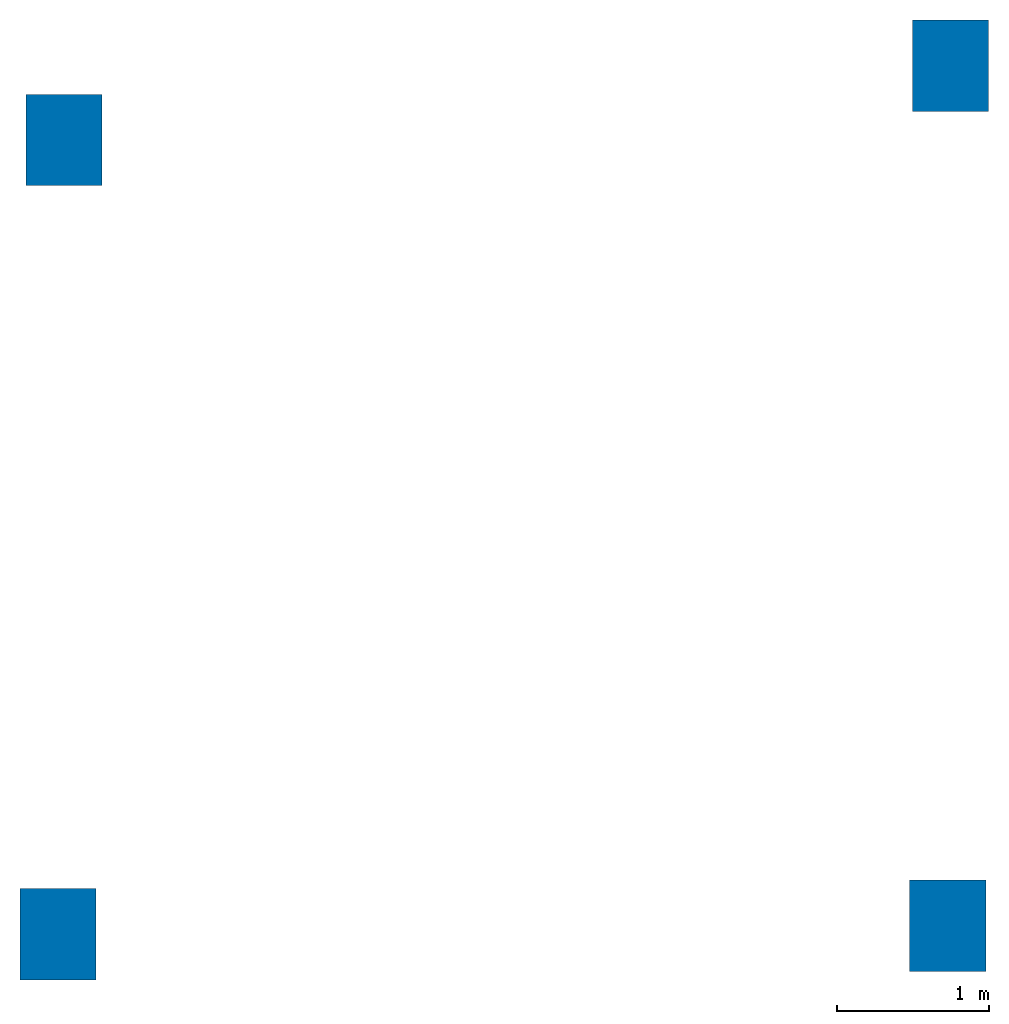
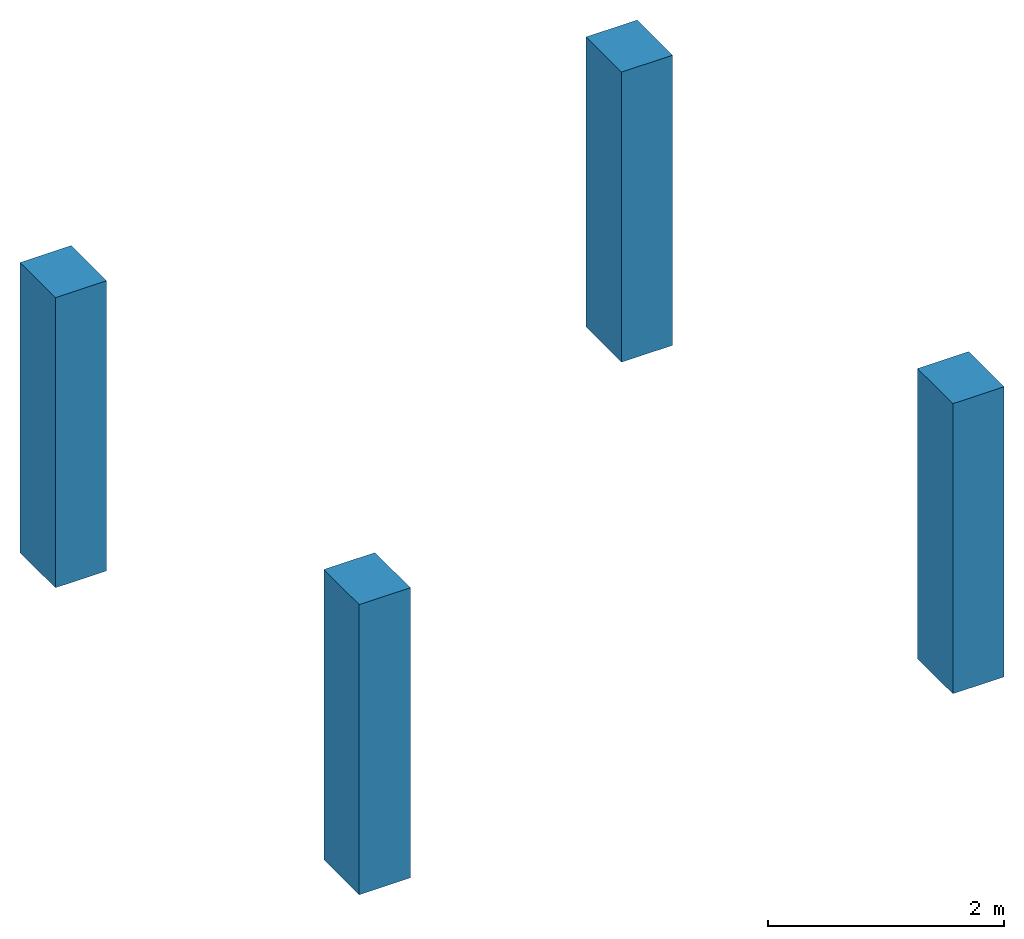
# One storey: 4 columns.
"""IFC4 building model written with IfcOpenShell, lengths in millimetres."""

import ifcopenshell
import ifcopenshell.guid

model = None  # the IFC model being written
_history = None  # IfcOwnerHistory: only IFC2X3 demands one
_inside = {}  # id of a spatial element -> (the spatial element, [elements in it])
_under = {}  # id of a project, library or spatial element -> (it, [spatial elements below it])
_declared = {}  # id of a project -> (the project, [libraries it declares])
_typed = {}  # id of a type object -> (the type object, [elements of that type])
_made_of = {}  # id of a material, layer set ... -> (it, [elements and type objects made of it])


def new_model(schema):
    """Start an empty IFC model of exactly this schema.

    Asked for "IFC4X3", IfcOpenShell would pick the latest addendum, in which some entities
    have other attributes; the version numbers below select the first issue.
    IFC2X3 requires an IfcOwnerHistory on every rooted entity: one is made here for all.
    """
    global model, _history
    if schema == "IFC4X3":
        model = ifcopenshell.file(schema_version=(4, 3, 0, 0))
    else:
        model = ifcopenshell.file(schema=schema)
    _inside.clear()
    _under.clear()
    _declared.clear()
    _typed.clear()
    _made_of.clear()
    _history = None
    if model.schema == "IFC2X3":
        org = make("IfcOrganization", Name="unknown")
        user = make(
            "IfcPersonAndOrganization",
            ThePerson=make("IfcPerson", FamilyName="unknown"),
            TheOrganization=org,
        )
        app = make(
            "IfcApplication",
            ApplicationDeveloper=org,
            Version="unknown",
            ApplicationFullName="unknown",
            ApplicationIdentifier="unknown",
        )
        _history = make(
            "IfcOwnerHistory",
            OwningUser=user,
            OwningApplication=app,
            ChangeAction="ADDED",
            CreationDate=0,
        )
    return model


def make(cls, **values):
    """One entity of the class cls with the attributes given. An attribute that is None is left unset."""
    return model.create_entity(
        cls, **{name: value for name, value in values.items() if value is not None}
    )


def entity(cls, *values):
    """Any entity or typed value of the class cls, its attributes in the order of the schema. None: left unset."""
    e = model.create_entity(cls)
    for i, value in enumerate(values):
        if value is not None:
            e[i] = value
    return e


def rooted(cls, **values):
    """An entity with a GlobalId (a new one), such as an element, a storey or a relation."""
    return make(cls, GlobalId=ifcopenshell.guid.new(), OwnerHistory=_history, **values)


def si_unit(unit_type, name, prefix=None):
    """IfcSIUnit, for example si_unit("LENGTHUNIT", "METRE", prefix="MILLI")."""
    return make("IfcSIUnit", UnitType=unit_type, Prefix=prefix, Name=name)


def converted_unit(unit_type, name, factor, base, dimensions=None, offset=None):
    """IfcConversionBasedUnit, such as the inch: factor (a typed value) times the base unit."""
    return make(
        "IfcConversionBasedUnit"
        if offset is None
        else "IfcConversionBasedUnitWithOffset",
        ConversionOffset=offset,
        Dimensions=None
        if dimensions is None
        else entity("IfcDimensionalExponents", *dimensions),
        UnitType=unit_type,
        Name=name,
        ConversionFactor=make(
            "IfcMeasureWithUnit", ValueComponent=factor, UnitComponent=base
        ),
    )


def assignment(units):
    """IfcUnitAssignment: the units of a project."""
    return None if units is None else make("IfcUnitAssignment", Units=units)


def point(xyz):
    """IfcCartesianPoint."""
    return None if xyz is None else make("IfcCartesianPoint", Coordinates=xyz)


def direction(xyz):
    """IfcDirection."""
    return None if xyz is None else make("IfcDirection", DirectionRatios=xyz)


def frame(location, z_axis=None, x_axis=None):
    """IfcAxis2Placement3D, a coordinate frame: its origin and axes. An axis left out is left unset."""
    return make(
        "IfcAxis2Placement3D",
        Location=point(location),
        Axis=direction(z_axis),
        RefDirection=direction(x_axis),
    )


def frame_2d(location, x_axis=None):
    """IfcAxis2Placement2D, a coordinate frame in the plane: its origin and x axis."""
    return make(
        "IfcAxis2Placement2D", Location=point(location), RefDirection=direction(x_axis)
    )


def origin_with_axes():
    """The frame at (0, 0, 0) with the z axis (0, 0, 1) and the x axis (1, 0, 0) written out."""
    return frame((0.0, 0.0, 0.0), z_axis=(0.0, 0.0, 1.0), x_axis=(1.0, 0.0, 0.0))


def origin_2d_with_axis():
    """The frame at (0, 0) in the plane with the x axis (1, 0) written out."""
    return frame_2d((0.0, 0.0), x_axis=(1.0, 0.0))


def place(relative_to, where):
    """IfcLocalPlacement: puts the frame where relative to a parent placement (None: the world)."""
    return make(
        "IfcLocalPlacement", PlacementRelTo=relative_to, RelativePlacement=where
    )


def context(
    kind, dimensions, precision=None, world=None, true_north=None, identifier=None
):
    """IfcGeometricRepresentationContext, for example the 3D "Model" context."""
    return make(
        "IfcGeometricRepresentationContext",
        ContextIdentifier=identifier,
        ContextType=kind,
        CoordinateSpaceDimension=dimensions,
        Precision=precision,
        WorldCoordinateSystem=world,
        TrueNorth=true_north,
    )


def subcontext(parent, identifier, kind, view, scale=None):
    """IfcGeometricRepresentationSubContext, for example "Body" below "Model"."""
    return make(
        "IfcGeometricRepresentationSubContext",
        ContextIdentifier=identifier,
        ContextType=kind,
        ParentContext=parent,
        TargetScale=scale,
        TargetView=view,
    )


def project(units=None, contexts=None):
    """IfcProject with its units and contexts."""
    return rooted(
        "IfcProject",
        Name="project",
        RepresentationContexts=contexts,
        UnitsInContext=assignment(units),
    )


def spatial(cls, under=None, at=None, **own):
    """A site, building, storey or space (cls), placed at a placement, below another one or the project."""
    s = rooted(cls, ObjectPlacement=at, **own)
    if under is not None:
        _under.setdefault(under.id(), (under, []))[1].append(s)
    return s


def profile(cls, at=None, kind="AREA", **sizes):
    """A parametric profile (cls). Its sizes go by their IFC names, for example OverallWidth=200.0."""
    return make(cls, ProfileType=kind, Position=at, **sizes)


def rectangle(**sizes):
    """IfcRectangleProfileDef."""
    return profile("IfcRectangleProfileDef", **sizes)


def extrude(swept, where, along, depth):
    """IfcExtrudedAreaSolid: the profile swept, set in the frame where, extruded along a direction by depth."""
    return make(
        "IfcExtrudedAreaSolid",
        SweptArea=swept,
        Position=where,
        ExtrudedDirection=direction(along),
        Depth=depth,
    )


def shape(context_of_items, identifier, shape_type, items):
    """IfcShapeRepresentation: the items that make up one representation, for example the "Body"."""
    return make(
        "IfcShapeRepresentation",
        ContextOfItems=context_of_items,
        RepresentationIdentifier=identifier,
        RepresentationType=shape_type,
        Items=items,
    )


def material(Name=None, Category=None):
    """IfcMaterial."""
    return make("IfcMaterial", Name=Name, Category=Category)


def material_profile(
    of_material, cross_section, Name=None, Category=None, Priority=None
):
    """IfcMaterialProfile: a cross section and its material."""
    return make(
        "IfcMaterialProfile",
        Name=Name,
        Material=of_material,
        Profile=cross_section,
        Priority=Priority,
        Category=Category,
    )


def profile_set(profiles, Name=None, composite=None):
    """IfcMaterialProfileSet."""
    return make(
        "IfcMaterialProfileSet",
        Name=Name,
        MaterialProfiles=profiles,
        CompositeProfile=composite,
    )


def profile_usage(for_profile_set, cardinal=None, extent=None):
    """IfcMaterialProfileSetUsage: how a profile set lies along its element."""
    return make(
        "IfcMaterialProfileSetUsage",
        ForProfileSet=for_profile_set,
        CardinalPoint=cardinal,
        ReferenceExtent=extent,
    )


def made_of(thing, what):
    """Note that an element or type object is made of a material, layer set ...; save() writes the relation."""
    if what is not None:
        _made_of.setdefault(what.id(), (what, []))[1].append(thing)
    return thing


def type_object(cls, material=None, **own):
    """A type object (cls), such as IfcWallType, which elements share."""
    return made_of(rooted(cls, **own), material)


def element(
    cls,
    number,
    at=None,
    inside=None,
    cuts=None,
    type_object=None,
    material=None,
    context=None,
    identifier="Body",
    shape_type=None,
    held_by="IfcProductDefinitionShape",
    body=None,
    shapes=None,
    **own,
):
    """One element of the class cls, such as IfcWall. Its Tag is "e" and its number.

    at: its placement. inside: the storey or other place that contains it. cuts: it is an
    opening in that element (IfcRelVoidsElement). A single representation is given by context,
    identifier, shape_type and body (its items); several are given by shapes. held_by: the class
    of the entity that holds the representations. save() writes the other relations.
    """
    e = rooted(cls, Tag="e%d" % number, ObjectPlacement=at, **own)
    if body is not None:
        shapes = [shape(context, identifier, shape_type, body)]
    if shapes is not None:
        e.Representation = make(held_by, Representations=shapes)
    if inside is not None:
        _inside.setdefault(inside.id(), (inside, []))[1].append(e)
    if cuts is not None:
        rooted(
            "IfcRelVoidsElement", RelatingBuildingElement=cuts, RelatedOpeningElement=e
        )
    if type_object is not None:
        _typed.setdefault(type_object.id(), (type_object, []))[1].append(e)
    return made_of(e, material)


def aggregate(whole, parts):
    """IfcRelAggregates: a whole, such as a stair, and the parts it consists of."""
    return rooted("IfcRelAggregates", RelatingObject=whole, RelatedObjects=parts)


def save(model, path):
    """Write the relations noted so far, then the file.

    IfcRelAggregates (storeys below a building ...), IfcRelContainedInSpatialStructure (elements
    in a storey), IfcRelDefinesByType, IfcRelAssociatesMaterial and IfcRelDeclares: one each for
    every whole, place, type object, material and project.
    """
    for whole, parts in _under.values():
        aggregate(whole, parts)
    for where, things in _inside.values():
        rooted(
            "IfcRelContainedInSpatialStructure",
            RelatedElements=things,
            RelatingStructure=where,
        )
    for kind, things in _typed.values():
        rooted("IfcRelDefinesByType", RelatedObjects=things, RelatingType=kind)
    for what, things in _made_of.values():
        rooted("IfcRelAssociatesMaterial", RelatedObjects=things, RelatingMaterial=what)
    for by, libraries in _declared.values():
        rooted("IfcRelDeclares", RelatingContext=by, RelatedDefinitions=libraries)
    model.write(path)


model = new_model("IFC4")

# Units and contexts
model_context = context("Model", 3, precision=1e-05, world=origin_with_axes())
plan_context = context("Plan", 2, precision=1e-05, world=origin_2d_with_axis())
body_context = subcontext(model_context, "Body", "Model", "MODEL_VIEW")
ifc_project = project(units=[si_unit("VOLUMEUNIT", "CUBIC_METRE"), si_unit("LENGTHUNIT", "METRE", prefix="MILLI"), converted_unit("PLANEANGLEUNIT", "degree", entity("IfcReal", 0.0174532925199433), si_unit("PLANEANGLEUNIT", "RADIAN"), dimensions=[0, 0, 0, 0, 0, 0, 0]), si_unit("AREAUNIT", "SQUARE_METRE")], contexts=[model_context, plan_context])

# Site, building, storey
site_placement = place(None, origin_with_axes())
site = spatial("IfcSite", under=ifc_project, at=site_placement)
building_placement = place(site_placement, origin_with_axes())
building = spatial("IfcBuilding", under=site, at=building_placement, Name="Building")
storey_placement = place(building_placement, origin_with_axes())
storey = spatial("IfcBuildingStorey", under=building, at=storey_placement, Name="Storey")

# Columns
ifc_material = material()
ifc_material_profile = material_profile(ifc_material, rectangle(XDim=500.0, YDim=600.0))
ifc_profile_set = profile_set([ifc_material_profile])
ifc_profile_usage_1 = profile_usage(ifc_profile_set, cardinal=5)
column_type = type_object("IfcColumnType", Name="C1", PredefinedType="NOTDEFINED", material=ifc_profile_set)
column_1_placement = place(storey_placement, frame((-2498.96478652954, -2937.89768218994, 0.0), z_axis=(0.0, 0.0, 1.0), x_axis=(1.0, 0.0, 0.0)))
element("IfcColumn", 1, at=column_1_placement, inside=storey, type_object=column_type, material=ifc_profile_usage_1, Name="Column", context=body_context, shape_type="SweptSolid", body=[
    extrude(rectangle(XDim=500.0, YDim=600.0), origin_with_axes(), (0.0, 0.0, 1.0), 3000.0),
])
ifc_profile_usage_2 = profile_usage(ifc_profile_set, cardinal=5)
column_2_placement = place(storey_placement, frame((-2460.95037460327, 2274.41215515137, 0.0), z_axis=(0.0, 0.0, 1.0), x_axis=(1.0, 0.0, 0.0)))
element("IfcColumn", 2, at=column_2_placement, inside=storey, type_object=column_type, material=ifc_profile_usage_2, Name="Column", context=body_context, shape_type="SweptSolid", body=[
    extrude(rectangle(XDim=500.0, YDim=600.0), origin_with_axes(), (0.0, 0.0, 1.0), 3000.0),
])
ifc_profile_usage_3 = profile_usage(ifc_profile_set, cardinal=5)
column_3_placement = place(storey_placement, frame((3356.99152946472, 2762.01820373535, 0.0), z_axis=(0.0, 0.0, 1.0), x_axis=(1.0, 0.0, 0.0)))
element("IfcColumn", 3, at=column_3_placement, inside=storey, type_object=column_type, material=ifc_profile_usage_3, Name="Column", context=body_context, shape_type="SweptSolid", body=[
    extrude(rectangle(XDim=500.0, YDim=600.0), origin_with_axes(), (0.0, 0.0, 1.0), 3000.0),
])
ifc_profile_usage_4 = profile_usage(ifc_profile_set, cardinal=5)
column_4_placement = place(storey_placement, frame((3339.48564529419, -2881.82020187378, 0.0), z_axis=(0.0, 0.0, 1.0), x_axis=(1.0, 0.0, 0.0)))
element("IfcColumn", 4, at=column_4_placement, inside=storey, type_object=column_type, material=ifc_profile_usage_4, Name="Column", context=body_context, shape_type="SweptSolid", body=[
    extrude(rectangle(XDim=500.0, YDim=600.0), origin_with_axes(), (0.0, 0.0, 1.0), 3000.0),
])

save(model, "model.ifc")
